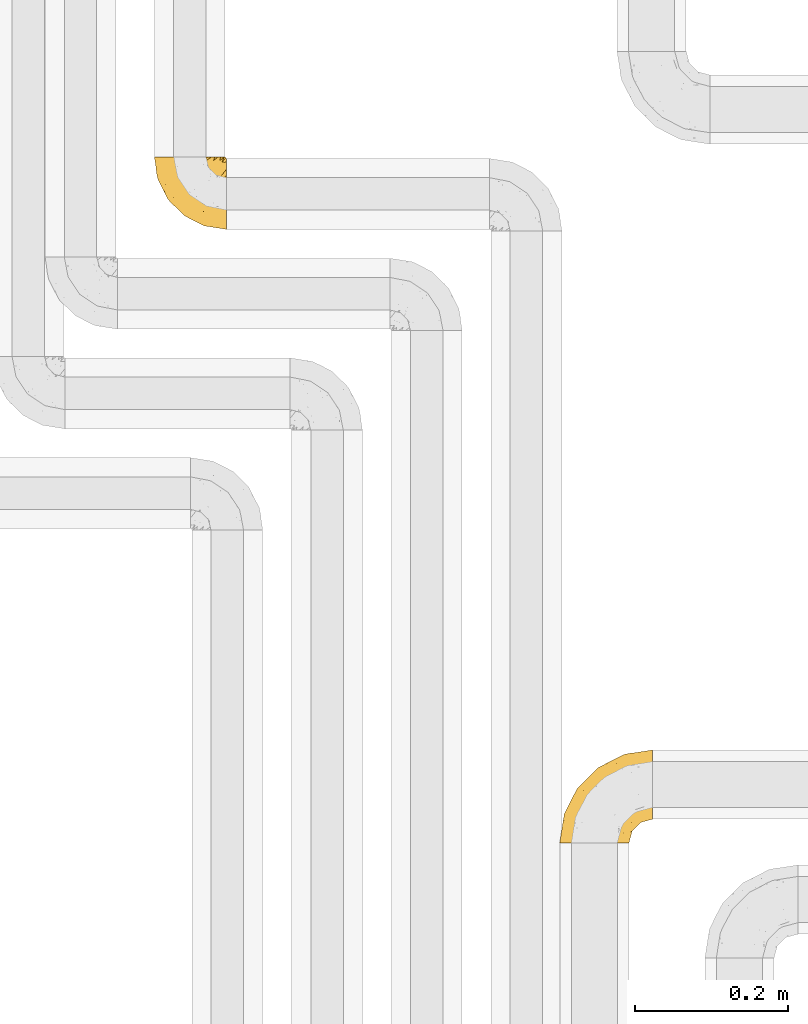
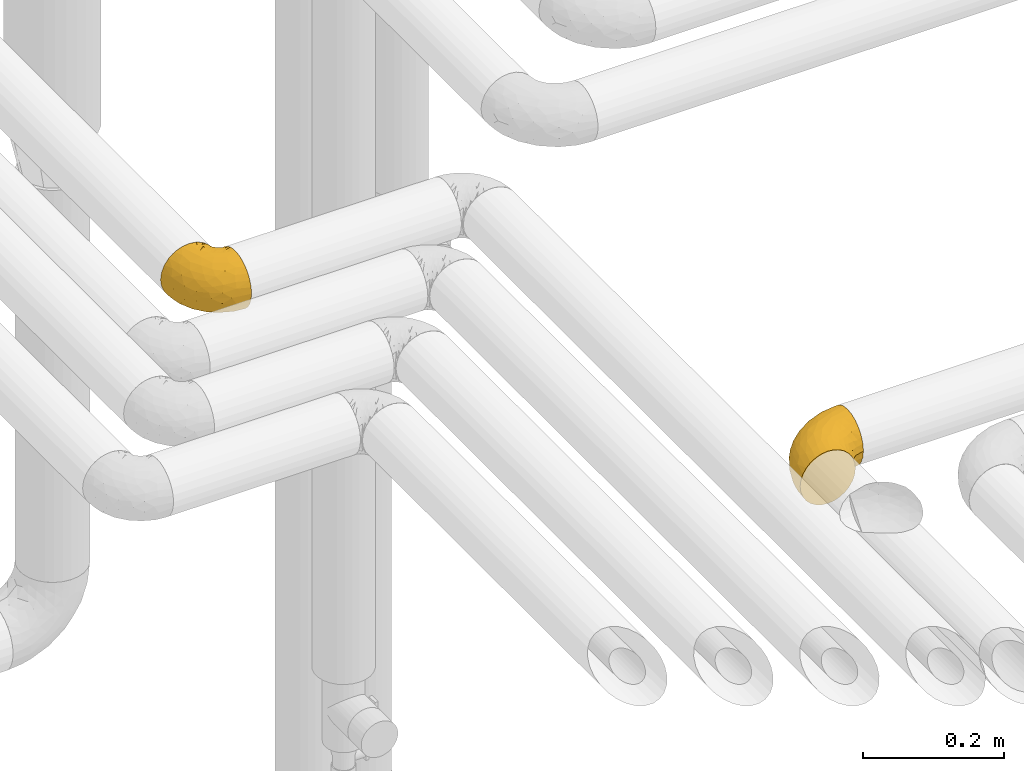
# One storey, part 263 of 827: 2 coverings.
"""IFC2X3 building model written with IfcOpenShell, lengths in millimetres."""

from ifc_helpers import new_model, entity, si_unit, converted_unit, derived_unit, direction, frame, origin, place, context, subcontext, project, spatial, faceted_brep, element, save


model = new_model("IFC2X3")

# Units and contexts
model_context = context("Model", 3, precision=0.01, world=origin(), true_north=direction((6.12303176911189e-17, 1.0)))
body_context = subcontext(model_context, "Body", "Model", "MODEL_VIEW")
ifc_project = project(units=[si_unit("LENGTHUNIT", "METRE", prefix="MILLI"), si_unit("AREAUNIT", "SQUARE_METRE"), si_unit("VOLUMEUNIT", "CUBIC_METRE"), converted_unit("PLANEANGLEUNIT", "DEGREE", entity("IfcRatioMeasure", 0.0174532925199433), si_unit("PLANEANGLEUNIT", "RADIAN"), dimensions=[0, 0, 0, 0, 0, 0, 0]), si_unit("MASSUNIT", "GRAM", prefix="KILO"), derived_unit("MASSDENSITYUNIT", [(si_unit("MASSUNIT", "GRAM", prefix="KILO"), 1), (si_unit("LENGTHUNIT", "METRE"), -3)]), derived_unit("MOMENTOFINERTIAUNIT", [(si_unit("LENGTHUNIT", "METRE"), 4)]), si_unit("TIMEUNIT", "SECOND"), si_unit("FREQUENCYUNIT", "HERTZ"), si_unit("THERMODYNAMICTEMPERATUREUNIT", "DEGREE_CELSIUS"), derived_unit("THERMALTRANSMITTANCEUNIT", [(si_unit("MASSUNIT", "GRAM", prefix="KILO"), 1), (si_unit("THERMODYNAMICTEMPERATUREUNIT", "KELVIN"), -1), (si_unit("TIMEUNIT", "SECOND"), -3)]), derived_unit("VOLUMETRICFLOWRATEUNIT", [(si_unit("LENGTHUNIT", "METRE"), 3), (si_unit("TIMEUNIT", "SECOND"), -1)]), derived_unit("MASSFLOWRATEUNIT", [(si_unit("MASSUNIT", "GRAM", prefix="KILO"), 1), (si_unit("TIMEUNIT", "SECOND"), -1)]), derived_unit("ROTATIONALFREQUENCYUNIT", [(si_unit("TIMEUNIT", "SECOND"), -1)]), si_unit("ELECTRICCURRENTUNIT", "AMPERE"), si_unit("ELECTRICVOLTAGEUNIT", "VOLT"), si_unit("POWERUNIT", "WATT"), si_unit("FORCEUNIT", "NEWTON", prefix="KILO"), si_unit("ILLUMINANCEUNIT", "LUX"), si_unit("LUMINOUSFLUXUNIT", "LUMEN"), si_unit("LUMINOUSINTENSITYUNIT", "CANDELA"), derived_unit("USERDEFINED", [(si_unit("MASSUNIT", "GRAM", prefix="KILO"), -1), (si_unit("LENGTHUNIT", "METRE"), -2), (si_unit("TIMEUNIT", "SECOND"), 3), (si_unit("LUMINOUSFLUXUNIT", "LUMEN"), 1)]), derived_unit("LINEARVELOCITYUNIT", [(si_unit("LENGTHUNIT", "METRE"), 1), (si_unit("TIMEUNIT", "SECOND"), -1)]), si_unit("PRESSUREUNIT", "PASCAL"), derived_unit("USERDEFINED", [(si_unit("LENGTHUNIT", "METRE"), -2), (si_unit("MASSUNIT", "GRAM", prefix="KILO"), 1), (si_unit("TIMEUNIT", "SECOND"), -2)]), derived_unit("LINEARFORCEUNIT", [(si_unit("MASSUNIT", "GRAM", prefix="KILO"), 1), (si_unit("LENGTHUNIT", "METRE"), 1), (si_unit("TIMEUNIT", "SECOND"), -2), (si_unit("LENGTHUNIT", "METRE"), -1)]), derived_unit("PLANARFORCEUNIT", [(si_unit("MASSUNIT", "GRAM", prefix="KILO"), 1), (si_unit("LENGTHUNIT", "METRE"), 1), (si_unit("TIMEUNIT", "SECOND"), -2), (si_unit("LENGTHUNIT", "METRE"), -2)])], contexts=[model_context])

# Site, building, storey
site_placement = place(None, origin())
site = spatial("IfcSite", under=ifc_project, at=site_placement, CompositionType="ELEMENT")
building_placement = place(site_placement, origin())
building = spatial("IfcBuilding", under=site, at=building_placement, CompositionType="ELEMENT")
storey_placement = place(building_placement, frame((0.0, 0.0, 28200.0)))
storey = spatial("IfcBuildingStorey", under=building, at=storey_placement, Name="08", CompositionType="ELEMENT", Elevation=28200.0)

# Coverings
covering_1_placement = place(storey_placement, frame((30819.81, 17333.41, 2952.2)))
element("IfcCovering", 1, at=covering_1_placement, inside=storey, Name=":ADSK_", ObjectType=":ADSK_", PredefinedType="INSULATION", context=body_context, shape_type="Brep", body=[
    faceted_brep([(95.8, 18.98, 83.91), (95.8, 11.67, 76.59), (95.8, 6.17, 67.83), (95.8, 2.75, 58.07), (95.8, 1.6, 47.8), (95.8, 2.75, 37.51), (95.8, 6.17, 27.74), (95.8, 11.68, 18.98), (95.8, 19.0, 11.67), (95.8, 27.76, 6.17), (95.8, 37.52, 2.75), (95.8, 47.8, 1.6), (95.8, 51.94, 2.06), (95.8, 55.01, 2.41), (95.8, 58.08, 2.75), (95.8, 62.96, 4.46), (95.8, 67.85, 6.17), (95.8, 72.23, 8.93), (95.8, 76.61, 11.68), (95.8, 80.26, 15.34), (95.8, 83.92, 19.0), (95.8, 89.42, 27.76), (95.8, 91.13, 32.64), (95.8, 92.84, 37.52), (95.8, 94.0, 47.8), (95.8, 92.84, 58.08), (95.8, 91.13, 62.96), (95.8, 89.42, 67.85), (95.8, 83.91, 76.61), (95.8, 80.25, 80.26), (95.8, 76.59, 83.92), (95.8, 72.21, 86.67), (95.8, 67.83, 89.42), (95.8, 62.95, 91.13), (95.8, 58.07, 92.84), (95.8, 55.0, 93.18), (95.8, 51.94, 93.53), (95.8, 47.8, 94.0), (95.8, 37.51, 92.84), (95.8, 27.74, 89.42), (94.0, 95.8, 47.8), (92.42, 95.8, 35.84), (87.81, 95.8, 24.7), (84.13, 95.8, 19.91), (80.46, 95.8, 15.13), (75.68, 95.8, 11.46), (70.9, 95.8, 7.78), (65.32, 95.8, 5.48), (59.75, 95.8, 3.17), (56.14, 95.8, 2.69), (54.06, 95.8, 2.42), (51.97, 95.8, 2.14), (47.8, 95.8, 1.6), (35.84, 95.8, 3.17), (24.7, 95.8, 7.78), (15.13, 95.8, 15.13), (7.78, 95.8, 24.7), (3.17, 95.8, 35.84), (1.6, 95.8, 47.8), (3.17, 95.8, 59.75), (7.78, 95.8, 70.9), (15.13, 95.8, 80.46), (24.7, 95.8, 87.81), (35.84, 95.8, 92.42), (47.8, 95.8, 94.0), (51.97, 95.8, 93.45), (56.14, 95.8, 92.9), (59.75, 95.8, 92.42), (65.32, 95.8, 90.11), (70.9, 95.8, 87.81), (75.68, 95.8, 84.13), (80.46, 95.8, 80.46), (84.13, 95.8, 75.68), (87.81, 95.8, 70.9), (92.42, 95.8, 59.75), (15.84, 60.58, 71.98), (6.99, 74.11, 63.6), (14.39, 51.59, 59.72), (6.21, 66.69, 47.8), (4.26, 76.19, 55.16), (3.39, 84.43, 47.8), (31.2, 31.2, 63.76), (26.47, 42.88, 72.22), (11.44, 79.41, 74.18), (47.66, 60.7, 92.52), (61.85, 61.85, 94.0), (59.25, 65.75, 94.0), (56.65, 69.64, 94.0), (54.05, 73.53, 94.0), (51.45, 77.43, 94.0), (19.8, 74.59, 82.14), (26.22, 54.72, 80.34), (31.58, 64.18, 87.52), (38.36, 37.94, 79.59), (51.54, 25.89, 78.25), (51.6, 34.73, 85.01), (55.97, 42.89, 90.25), (62.88, 49.83, 93.2), (41.35, 48.58, 87.23), (82.24, 22.41, 85.55), (40.88, 78.69, 93.0), (29.0, 81.64, 89.31), (74.06, 6.22, 61.31), (54.53, 12.11, 56.86), (57.98, 14.81, 68.34), (43.81, 21.61, 65.71), (38.22, 22.41, 56.99), (38.33, 30.12, 72.15), (74.76, 10.01, 70.34), (76.85, 15.36, 78.36), (84.43, 3.39, 47.8), (40.43, 19.59, 47.8), (30.01, 30.01, 47.8), (78.67, 41.19, 93.06), (92.06, 48.54, 94.0), (88.32, 49.28, 94.0), (85.6, 49.82, 94.0), (82.88, 50.37, 94.0), (80.15, 50.91, 94.0), (77.43, 51.45, 94.0), (76.36, 31.61, 89.88), (50.91, 80.15, 94.0), (50.37, 82.88, 94.0), (49.82, 85.6, 94.0), (49.28, 88.32, 94.0), (48.91, 90.19, 94.0), (48.54, 92.06, 94.0), (66.69, 6.21, 47.8), (73.53, 54.05, 94.0), (69.64, 56.65, 94.0), (65.75, 59.25, 94.0), (66.13, 24.66, 83.7), (19.59, 40.43, 47.8), (24.64, 35.17, 55.9), (53.56, 12.9, 47.8), (12.9, 53.56, 47.8), (82.81, 85.34, 81.75), (81.22, 78.44, 86.43), (86.57, 84.37, 79.8), (92.75, 89.05, 69.84), (89.68, 82.76, 79.5), (72.26, 86.31, 88.08), (64.73, 83.73, 91.6), (62.45, 77.31, 92.93), (60.63, 87.78, 92.43), (56.91, 87.91, 93.24), (58.14, 81.29, 93.36), (93.7, 93.97, 57.25), (83.4, 70.76, 89.41), (75.54, 63.67, 92.89), (79.46, 62.62, 92.66), (82.28, 90.64, 79.58), (76.25, 84.08, 86.51), (84.69, 76.28, 86.29), (90.18, 77.45, 83.91), (65.12, 88.72, 90.94), (71.71, 71.28, 91.94), (75.21, 68.09, 91.98), (78.6, 91.07, 82.79), (87.27, 57.47, 93.16), (87.92, 70.34, 88.76), (86.94, 91.35, 73.94), (86.1, 62.99, 91.89), (94.52, 94.52, 47.8), (66.23, 76.47, 92.22), (91.08, 69.96, 88.56), (71.77, 89.86, 87.72), (76.21, 78.94, 88.33), (68.59, 73.51, 92.18), (89.94, 89.62, 71.78), (76.25, 84.09, 9.09), (72.26, 86.3, 7.51), (78.6, 91.06, 12.8), (49.28, 88.32, 1.6), (48.54, 92.06, 1.6), (50.37, 82.88, 1.6), (49.82, 85.6, 1.6), (93.7, 93.97, 38.35), (89.95, 89.63, 23.84), (82.88, 50.37, 1.6), (85.6, 49.82, 1.6), (92.06, 48.54, 1.6), (88.32, 49.28, 1.6), (89.68, 82.77, 16.1), (87.92, 70.36, 6.84), (62.45, 77.31, 2.66), (66.24, 76.47, 3.37), (56.65, 69.64, 1.6), (59.25, 65.75, 1.6), (60.63, 87.78, 3.16), (56.91, 87.91, 2.35), (92.76, 89.06, 25.77), (82.28, 90.65, 16.02), (82.81, 85.35, 13.85), (54.05, 73.53, 1.6), (51.45, 77.43, 1.6), (58.14, 81.29, 2.23), (90.18, 77.46, 11.69), (84.7, 76.29, 9.31), (87.25, 57.47, 2.43), (75.58, 63.71, 2.71), (75.2, 68.11, 3.61), (83.39, 70.77, 6.18), (71.7, 71.31, 3.66), (81.22, 78.46, 9.17), (90.73, 69.52, 6.77), (79.47, 62.64, 2.93), (86.94, 91.35, 21.66), (65.75, 59.25, 1.6), (86.75, 84.6, 16.09), (86.08, 62.98, 3.7), (77.43, 51.45, 1.6), (73.53, 54.05, 1.6), (69.64, 56.65, 1.6), (64.73, 83.73, 3.99), (50.91, 80.15, 1.6), (65.12, 88.72, 4.65), (61.85, 61.85, 1.6), (68.62, 73.56, 3.43), (76.22, 78.96, 7.27), (74.03, 91.36, 9.46), (80.15, 50.91, 1.6), (49.81, 62.87, 2.4), (4.26, 76.19, 40.43), (19.95, 73.57, 13.57), (30.61, 56.07, 11.3), (25.71, 49.77, 18.65), (22.43, 44.73, 27.26), (15.85, 60.58, 23.61), (60.69, 47.64, 3.07), (40.49, 78.32, 2.69), (14.39, 51.59, 35.87), (6.99, 74.11, 31.99), (29.56, 76.04, 6.71), (11.45, 79.41, 21.41), (57.98, 14.82, 27.24), (74.06, 6.22, 34.26), (54.52, 12.12, 38.73), (43.47, 23.51, 26.97), (31.2, 31.2, 31.83), (33.27, 34.96, 23.4), (64.26, 33.86, 6.91), (74.29, 38.94, 3.4), (80.41, 30.23, 5.84), (41.67, 20.67, 35.73), (24.64, 35.17, 39.69), (73.62, 15.85, 17.6), (78.98, 22.59, 10.38), (53.69, 21.56, 20.6), (42.86, 55.94, 5.36), (79.66, 9.19, 24.84), (58.41, 25.79, 13.87), (47.11, 41.16, 9.06), (38.37, 37.95, 15.99)], [[[0, 1, 2, 3, 4, 5, 6, 7, 8, 9, 10, 11, 12, 13, 14, 15, 16, 17, 18, 19, 20, 21, 22, 23, 24, 25, 26, 27, 28, 29, 30, 31, 32, 33, 34, 35, 36, 37, 38, 39]], [[40, 41, 42, 43, 44, 45, 46, 47, 48, 49, 50, 51, 52, 53, 54, 55, 56, 57, 58, 59, 60, 61, 62, 63, 64, 65, 66, 67, 68, 69, 70, 71, 72, 73, 74]], [[75, 76, 77]], [[78, 79, 80]], [[77, 81, 82]], [[76, 75, 83]], [[84, 85, 86, 87, 88, 89]], [[90, 91, 92]], [[76, 60, 59]], [[93, 94, 95]], [[90, 62, 61]], [[83, 61, 60]], [[96, 97, 84]], [[98, 93, 95]], [[0, 39, 99]], [[100, 84, 89]], [[62, 101, 63]], [[2, 102, 3]], [[92, 84, 100]], [[103, 102, 104]], [[103, 105, 106]], [[93, 107, 94]], [[1, 108, 2]], [[92, 101, 90]], [[108, 1, 109]], [[102, 110, 3]], [[93, 82, 107]], [[102, 108, 104]], [[111, 106, 112]], [[109, 0, 99]], [[113, 37, 114, 115, 116, 117, 118, 119]], [[120, 38, 113]], [[100, 89, 121, 122, 123, 124, 125, 126, 64]], [[127, 102, 103]], [[97, 119, 128, 129, 130, 85]], [[99, 120, 131]], [[132, 133, 77]], [[59, 80, 79]], [[1, 0, 109]], [[98, 84, 92]], [[94, 109, 131]], [[120, 39, 38]], [[93, 91, 82]], [[104, 94, 105]], [[97, 113, 119]], [[95, 120, 96]], [[83, 90, 61]], [[91, 93, 98]], [[64, 63, 100]], [[100, 63, 101]], [[77, 76, 79]], [[133, 106, 81]], [[84, 97, 85]], [[113, 96, 120]], [[113, 97, 96]], [[37, 113, 38]], [[110, 102, 127]], [[110, 4, 3]], [[103, 111, 134, 127]], [[90, 75, 91]], [[82, 81, 107]], [[91, 75, 82]], [[77, 82, 75]], [[76, 83, 60]], [[90, 83, 75]], [[105, 107, 81]], [[94, 131, 95]], [[105, 94, 107]], [[109, 94, 104]], [[120, 95, 131]], [[98, 95, 96]], [[84, 98, 96]], [[98, 92, 91]], [[106, 105, 81]], [[103, 104, 105]], [[133, 132, 112]], [[103, 106, 111]], [[77, 78, 135, 132]], [[106, 133, 112]], [[77, 133, 81]], [[120, 99, 39]], [[109, 99, 131]], [[59, 58, 80]], [[59, 79, 76]], [[90, 101, 62]], [[100, 101, 92]], [[2, 108, 102]], [[109, 104, 108]], [[78, 77, 79]], [[136, 137, 138]], [[27, 139, 140]], [[141, 142, 143]], [[144, 145, 121]], [[146, 89, 88]], [[147, 139, 25]], [[148, 149, 150]], [[136, 151, 152]], [[147, 40, 74]], [[24, 147, 25]], [[140, 153, 154]], [[33, 116, 34]], [[73, 72, 151]], [[114, 37, 36, 35, 34, 116, 115]], [[146, 155, 144]], [[156, 85, 130]], [[157, 149, 148]], [[151, 158, 152]], [[117, 33, 159]], [[29, 154, 160]], [[161, 74, 73]], [[162, 128, 119]], [[66, 65, 64, 126, 125, 124, 123, 122, 67]], [[163, 147, 24]], [[27, 140, 28]], [[149, 129, 150]], [[139, 27, 26, 25]], [[68, 144, 69]], [[129, 128, 150]], [[164, 87, 86]], [[130, 129, 149]], [[122, 145, 67]], [[154, 153, 148]], [[162, 119, 159]], [[165, 30, 160]], [[150, 160, 148]], [[128, 162, 150]], [[30, 165, 31]], [[145, 144, 68]], [[89, 146, 144]], [[87, 164, 143]], [[166, 155, 142]], [[88, 87, 143]], [[162, 160, 150]], [[160, 30, 29]], [[154, 29, 28]], [[140, 154, 28]], [[160, 154, 148]], [[140, 137, 153]], [[157, 148, 153]], [[156, 130, 157]], [[153, 137, 157]], [[157, 137, 156]], [[167, 137, 136]], [[168, 85, 156]], [[152, 168, 167]], [[167, 168, 156]], [[164, 152, 141]], [[71, 158, 72]], [[152, 167, 136]], [[88, 142, 146]], [[144, 155, 69]], [[146, 142, 155]], [[70, 166, 71]], [[142, 141, 166]], [[70, 69, 155]], [[141, 158, 71]], [[161, 73, 151]], [[138, 137, 140]], [[161, 136, 169]], [[136, 161, 151]], [[74, 161, 169]], [[152, 158, 141]], [[151, 72, 158]], [[168, 152, 164]], [[137, 167, 156]], [[164, 86, 168]], [[85, 168, 86]], [[116, 33, 117]], [[130, 149, 157]], [[67, 145, 68]], [[121, 89, 144]], [[145, 122, 121]], [[40, 147, 163]], [[169, 147, 74]], [[159, 33, 32]], [[162, 159, 32]], [[159, 119, 118, 117]], [[139, 147, 169]], [[139, 169, 138]], [[162, 32, 31]], [[141, 143, 164]], [[88, 143, 142]], [[71, 166, 141]], [[155, 166, 70]], [[139, 138, 140]], [[169, 136, 138]], [[160, 162, 165]], [[162, 31, 165]], [[170, 171, 172]], [[173, 174, 52, 51, 50, 49, 48, 175, 176]], [[177, 178, 41]], [[179, 15, 180]], [[12, 11, 181, 182, 180, 14, 13]], [[183, 21, 20]], [[19, 18, 184]], [[185, 186, 187]], [[186, 188, 187]], [[43, 172, 44]], [[189, 190, 47]], [[23, 22, 21, 191]], [[170, 192, 193]], [[40, 163, 177]], [[194, 195, 196]], [[24, 23, 177]], [[197, 198, 183]], [[199, 15, 179]], [[47, 46, 189]], [[200, 201, 202]], [[201, 203, 204]], [[205, 206, 184]], [[207, 41, 178]], [[16, 15, 199]], [[14, 180, 15]], [[202, 201, 198]], [[208, 201, 200]], [[163, 24, 177]], [[48, 47, 190]], [[196, 195, 189]], [[197, 184, 202]], [[204, 193, 209]], [[210, 211, 212]], [[206, 212, 213]], [[205, 17, 210]], [[184, 206, 202]], [[210, 212, 206]], [[185, 194, 214]], [[189, 215, 190]], [[216, 45, 214]], [[186, 171, 170]], [[189, 216, 196]], [[197, 20, 19]], [[194, 185, 187]], [[197, 183, 20]], [[184, 197, 19]], [[197, 202, 198]], [[206, 200, 202]], [[204, 183, 198]], [[201, 208, 203]], [[203, 208, 217]], [[204, 198, 201]], [[217, 188, 218]], [[193, 219, 170]], [[171, 186, 185]], [[170, 218, 186]], [[170, 219, 218]], [[42, 207, 192]], [[171, 220, 172]], [[216, 189, 46]], [[214, 194, 196]], [[44, 220, 45]], [[214, 196, 216]], [[216, 46, 45]], [[214, 45, 220]], [[192, 43, 42]], [[204, 203, 219]], [[207, 193, 192]], [[209, 193, 178]], [[41, 207, 42]], [[193, 207, 178]], [[43, 192, 172]], [[170, 172, 192]], [[204, 219, 193]], [[219, 203, 218]], [[217, 218, 203]], [[188, 186, 218]], [[206, 213, 200]], [[208, 200, 213]], [[199, 210, 16]], [[215, 189, 195]], [[215, 175, 190]], [[175, 48, 190]], [[199, 179, 221, 211]], [[210, 199, 211]], [[23, 191, 177]], [[40, 177, 41]], [[178, 177, 191]], [[21, 183, 191]], [[209, 191, 183]], [[205, 18, 17]], [[17, 16, 210]], [[171, 185, 214]], [[172, 220, 44]], [[214, 220, 171]], [[191, 209, 178]], [[204, 209, 183]], [[206, 205, 210]], [[18, 205, 184]], [[222, 195, 194, 187, 188, 217]], [[57, 223, 80]], [[224, 225, 226]], [[226, 227, 228]], [[229, 217, 208, 213, 212, 211]], [[230, 52, 174, 173, 176, 175, 215, 195]], [[231, 232, 228]], [[231, 78, 223]], [[223, 57, 232]], [[224, 233, 225]], [[233, 54, 53]], [[234, 232, 56]], [[56, 55, 234]], [[234, 224, 228]], [[235, 236, 237]], [[224, 55, 54]], [[238, 239, 240]], [[52, 230, 53]], [[241, 242, 243]], [[239, 244, 245]], [[11, 10, 242]], [[236, 6, 5]], [[7, 246, 8]], [[8, 247, 9]], [[238, 248, 235]], [[222, 229, 249]], [[242, 211, 221, 179, 180, 182, 181, 11]], [[233, 53, 230]], [[111, 112, 244]], [[250, 6, 236]], [[247, 251, 241]], [[6, 250, 7]], [[127, 236, 110]], [[249, 229, 252]], [[247, 8, 246]], [[235, 246, 250]], [[236, 5, 110]], [[235, 244, 238]], [[237, 236, 127]], [[243, 9, 247]], [[252, 229, 241]], [[56, 232, 57]], [[222, 230, 195]], [[225, 249, 252]], [[249, 233, 230]], [[54, 233, 224]], [[231, 228, 227]], [[245, 132, 231]], [[249, 225, 233]], [[226, 225, 253]], [[235, 250, 236]], [[246, 7, 250]], [[251, 247, 246]], [[243, 247, 241]], [[248, 246, 235]], [[252, 251, 253]], [[229, 222, 217]], [[230, 222, 249]], [[5, 4, 110]], [[237, 127, 134, 111]], [[238, 244, 239]], [[224, 234, 55]], [[232, 234, 228]], [[242, 241, 229]], [[10, 9, 243]], [[211, 242, 229]], [[10, 243, 242]], [[80, 223, 78]], [[80, 58, 57]], [[231, 223, 232]], [[227, 240, 239]], [[224, 226, 228]], [[240, 226, 253]], [[227, 239, 245]], [[226, 240, 227]], [[251, 248, 253]], [[240, 253, 248]], [[244, 235, 237]], [[237, 111, 244]], [[132, 245, 112]], [[112, 245, 244]], [[135, 78, 231, 132]], [[227, 245, 231]], [[248, 238, 240]], [[246, 248, 251]], [[251, 252, 241]], [[225, 252, 253]]]),
])
covering_2_placement = place(storey_placement, frame((31348.29, 16533.61, 2953.25)))
element("IfcCovering", 2, at=covering_2_placement, inside=storey, Name=":ADSK_", ObjectType=":ADSK_", PredefinedType="INSULATION", context=body_context, shape_type="Brep", body=[
    faceted_brep([(36.69, 1.6, 90.76), (27.15, 1.6, 87.42), (18.59, 1.6, 82.04), (11.44, 1.6, 74.89), (6.06, 1.6, 66.33), (2.73, 1.6, 56.79), (1.6, 1.6, 46.75), (2.73, 1.6, 36.69), (6.07, 1.6, 27.15), (11.45, 1.6, 18.59), (18.6, 1.6, 11.44), (27.16, 1.6, 6.06), (36.7, 1.6, 2.73), (46.75, 1.6, 1.6), (56.8, 1.6, 2.73), (66.34, 1.6, 6.07), (74.9, 1.6, 11.45), (82.05, 1.6, 18.6), (87.43, 1.6, 27.16), (90.76, 1.6, 36.7), (91.9, 1.6, 46.75), (90.76, 1.6, 56.8), (87.42, 1.6, 66.34), (82.04, 1.6, 74.9), (74.89, 1.6, 82.05), (66.33, 1.6, 87.43), (56.79, 1.6, 90.76), (46.75, 1.6, 91.9), (122.75, 33.98, 35.06), (122.75, 38.49, 24.17), (122.75, 45.67, 14.82), (122.75, 55.02, 7.64), (122.75, 65.91, 3.13), (122.75, 77.6, 1.6), (122.75, 89.28, 3.13), (122.75, 100.17, 7.64), (122.75, 109.52, 14.82), (122.75, 116.7, 24.17), (122.75, 121.21, 35.06), (122.75, 122.75, 46.75), (122.75, 121.21, 58.43), (122.75, 116.7, 69.32), (122.75, 109.52, 78.67), (122.75, 100.17, 85.85), (122.75, 89.28, 90.36), (122.75, 77.6, 91.9), (122.75, 65.91, 90.36), (122.75, 55.02, 85.85), (122.75, 45.67, 78.67), (122.75, 38.49, 69.32), (122.75, 33.98, 58.43), (122.75, 32.45, 46.75), (24.73, 72.81, 46.75), (29.08, 77.17, 55.2), (38.13, 86.21, 46.75), (85.31, 116.82, 46.75), (93.59, 118.49, 54.53), (100.54, 119.23, 46.75), (63.54, 105.14, 59.63), (38.98, 85.37, 62.07), (50.71, 89.33, 71.86), (93.33, 116.14, 62.65), (75.2, 105.06, 71.33), (100.46, 112.15, 72.93), (41.6, 22.95, 91.2), (80.86, 89.91, 86.31), (94.87, 103.39, 80.89), (67.96, 93.6, 79.49), (52.16, 51.41, 90.68), (52.1, 67.71, 86.84), (36.74, 43.53, 87.38), (17.11, 30.91, 76.87), (23.24, 23.58, 83.73), (29.18, 50.07, 81.03), (52.53, 30.68, 91.9), (60.77, 43.01, 91.9), (69.01, 55.34, 91.9), (100.68, 83.48, 91.03), (103.79, 94.96, 87.58), (16.37, 57.29, 56.52), (7.52, 39.03, 46.75), (7.31, 30.66, 60.4), (93.66, 71.81, 91.9), (102.83, 73.63, 91.9), (112.01, 75.46, 91.9), (18.17, 51.57, 67.87), (71.97, 73.13, 90.35), (9.83, 23.16, 69.57), (5.11, 23.8, 46.75), (45.97, 75.6, 79.91), (48.88, 12.33, 91.9), (50.71, 21.51, 91.9), (22.83, 50.46, 74.99), (51.54, 99.61, 46.75), (81.33, 63.57, 91.9), (31.74, 21.26, 88.53), (32.48, 69.54, 72.65), (68.42, 108.21, 46.75), (25.33, 68.42, 62.97), (16.13, 55.92, 46.75), (92.29, 19.36, 66.2), (94.12, 15.76, 56.6), (100.97, 26.13, 59.89), (95.91, 62.78, 90.95), (107.9, 63.65, 90.22), (87.24, 24.34, 76.64), (95.46, 28.46, 71.58), (90.41, 33.53, 79.99), (74.17, 39.46, 89.54), (83.77, 51.05, 89.97), (76.72, 10.94, 81.32), (84.44, 14.55, 74.56), (76.42, 22.21, 84.15), (90.07, 57.05, 90.37), (99.69, 54.0, 87.82), (61.74, 29.19, 90.98), (58.16, 18.85, 90.96), (112.6, 52.84, 85.14), (110.45, 31.47, 58.11), (107.32, 28.31, 46.75), (108.48, 43.0, 78.39), (66.63, 16.9, 88.22), (115.23, 35.98, 66.06), (105.79, 33.91, 68.6), (89.6, 9.97, 63.78), (69.39, 25.93, 88.42), (66.99, 35.61, 90.61), (102.31, 47.45, 83.8), (99.54, 38.26, 77.98), (55.27, 11.7, 91.22), (82.03, 30.13, 83.46), (94.71, 12.12, 46.75), (96.03, 17.02, 46.75), (94.11, 44.39, 84.66), (84.21, 39.83, 86.33), (101.67, 22.67, 46.75), (112.22, 29.63, 46.75), (108.48, 43.0, 15.1), (102.31, 47.45, 9.69), (99.54, 38.26, 15.52), (94.11, 44.38, 8.83), (110.46, 31.47, 35.39), (76.74, 10.93, 12.18), (50.71, 21.51, 1.6), (58.17, 18.84, 2.53), (55.27, 11.7, 2.27), (94.12, 15.76, 36.9), (92.3, 19.36, 27.31), (100.98, 26.14, 33.62), (69.41, 25.94, 5.07), (76.44, 22.21, 9.36), (66.65, 16.9, 5.27), (115.24, 35.98, 27.43), (102.83, 73.63, 1.6), (112.01, 75.46, 1.6), (82.05, 30.12, 10.05), (87.25, 24.33, 16.87), (112.6, 52.84, 8.35), (107.9, 63.65, 3.27), (93.66, 71.81, 1.6), (95.48, 28.45, 21.94), (89.6, 9.97, 29.72), (60.77, 43.01, 1.6), (69.01, 55.34, 1.6), (74.17, 39.46, 3.96), (48.88, 12.33, 1.6), (84.45, 14.54, 18.95), (95.91, 62.78, 2.54), (90.07, 57.05, 3.12), (81.33, 63.57, 1.6), (61.75, 29.2, 2.51), (83.77, 51.05, 3.52), (84.21, 39.81, 7.17), (52.53, 30.68, 1.6), (90.42, 33.52, 13.52), (67.0, 35.61, 2.88), (99.69, 54.0, 5.67), (105.8, 33.91, 24.89), (94.87, 103.39, 12.6), (80.86, 89.91, 7.18), (67.95, 93.6, 14.0), (75.17, 105.05, 22.16), (50.65, 89.27, 21.61), (71.97, 73.13, 3.14), (52.08, 67.67, 6.65), (32.46, 69.49, 20.82), (38.98, 85.36, 31.41), (103.79, 94.96, 5.91), (100.68, 83.48, 2.46), (63.54, 105.14, 33.87), (93.32, 116.13, 30.84), (93.59, 118.49, 38.96), (100.44, 112.15, 20.56), (52.17, 51.41, 2.81), (36.75, 43.51, 6.1), (41.61, 22.95, 2.29), (7.31, 30.66, 33.08), (17.12, 30.91, 16.61), (16.37, 57.3, 36.96), (23.26, 23.58, 9.75), (18.17, 51.56, 25.61), (25.33, 68.41, 30.5), (9.84, 23.16, 23.91), (29.19, 50.07, 12.45), (22.84, 50.45, 18.49), (31.75, 21.25, 4.96), (45.96, 75.56, 13.56), (29.07, 77.16, 38.28)], [[[0, 1, 2, 3, 4, 5, 6, 7, 8, 9, 10, 11, 12, 13, 14, 15, 16, 17, 18, 19, 20, 21, 22, 23, 24, 25, 26, 27]], [[28, 29, 30, 31, 32, 33, 34, 35, 36, 37, 38, 39, 40, 41, 42, 43, 44, 45, 46, 47, 48, 49, 50, 51]], [[52, 53, 54]], [[55, 56, 57]], [[58, 59, 60]], [[61, 62, 63]], [[27, 64, 0]], [[65, 66, 67]], [[41, 40, 61]], [[68, 69, 70]], [[66, 43, 42]], [[63, 42, 41]], [[71, 72, 73]], [[72, 2, 1]], [[68, 74, 75, 76]], [[45, 44, 77]], [[43, 78, 44]], [[79, 80, 81]], [[77, 82, 83, 84, 45]], [[79, 81, 85]], [[71, 2, 72]], [[65, 86, 77]], [[4, 81, 5]], [[66, 65, 78]], [[4, 3, 87]], [[81, 88, 5]], [[63, 66, 42]], [[68, 70, 64]], [[67, 60, 89]], [[71, 3, 2]], [[64, 27, 90, 91, 74]], [[92, 71, 73]], [[40, 57, 56]], [[59, 93, 54]], [[86, 76, 94, 82]], [[1, 0, 95]], [[58, 62, 61]], [[60, 96, 89]], [[85, 81, 87]], [[56, 97, 58]], [[65, 67, 69]], [[87, 81, 4]], [[67, 89, 69]], [[61, 63, 41]], [[95, 72, 1]], [[73, 72, 70]], [[69, 73, 70]], [[73, 89, 96]], [[3, 71, 87]], [[85, 87, 71]], [[58, 61, 56]], [[59, 58, 93]], [[76, 86, 68]], [[69, 89, 73]], [[68, 86, 69]], [[65, 69, 86]], [[68, 64, 74]], [[95, 64, 70]], [[98, 79, 85]], [[79, 52, 99, 80]], [[66, 62, 67]], [[62, 58, 60]], [[62, 60, 67]], [[59, 98, 96]], [[59, 96, 60]], [[96, 85, 92]], [[88, 81, 80]], [[88, 6, 5]], [[66, 63, 62]], [[64, 95, 0]], [[72, 95, 70]], [[77, 44, 78]], [[86, 82, 77]], [[40, 39, 57]], [[96, 98, 85]], [[40, 56, 61]], [[66, 78, 43]], [[77, 78, 65]], [[79, 98, 53]], [[96, 92, 73]], [[85, 71, 92]], [[97, 56, 55]], [[97, 93, 58]], [[53, 98, 59]], [[54, 53, 59]], [[79, 53, 52]], [[100, 101, 102]], [[46, 45, 84, 83]], [[103, 104, 82]], [[82, 104, 83]], [[105, 106, 107]], [[108, 109, 76]], [[110, 111, 112]], [[103, 113, 114]], [[115, 74, 116]], [[48, 47, 117]], [[118, 102, 119]], [[49, 48, 120]], [[74, 91, 116]], [[116, 121, 115]], [[49, 122, 50]], [[123, 106, 102]], [[124, 111, 22]], [[125, 126, 115]], [[23, 22, 111]], [[24, 110, 121]], [[120, 127, 128]], [[90, 26, 129]], [[27, 26, 90]], [[121, 125, 115]], [[24, 121, 25]], [[130, 105, 107]], [[129, 25, 116]], [[21, 20, 131]], [[120, 123, 122]], [[112, 105, 130]], [[50, 118, 51]], [[21, 124, 22]], [[101, 131, 132]], [[117, 120, 48]], [[24, 23, 110]], [[127, 114, 133]], [[75, 108, 76]], [[107, 134, 130]], [[133, 114, 113]], [[129, 116, 91]], [[25, 121, 116]], [[121, 112, 125]], [[75, 74, 115]], [[101, 135, 102]], [[131, 101, 21]], [[101, 100, 124]], [[128, 127, 133]], [[119, 136, 51, 118]], [[104, 47, 46]], [[83, 104, 46]], [[117, 104, 114]], [[101, 124, 21]], [[111, 124, 100]], [[102, 118, 123]], [[133, 134, 107]], [[111, 110, 23]], [[114, 104, 103]], [[94, 76, 109]], [[121, 110, 112]], [[122, 118, 50]], [[134, 109, 108]], [[133, 107, 128]], [[112, 108, 125]], [[126, 125, 108]], [[108, 75, 126]], [[75, 115, 126]], [[109, 134, 133]], [[130, 108, 112]], [[108, 130, 134]], [[105, 112, 111]], [[111, 100, 105]], [[106, 105, 100]], [[102, 106, 100]], [[128, 106, 123]], [[90, 129, 91]], [[25, 129, 26]], [[104, 117, 47]], [[117, 114, 127]], [[82, 94, 103]], [[113, 94, 109]], [[94, 113, 103]], [[133, 113, 109]], [[106, 128, 107]], [[123, 120, 128]], [[120, 122, 49]], [[118, 122, 123]], [[135, 101, 132]], [[135, 119, 102]], [[117, 127, 120]], [[30, 29, 137]], [[138, 139, 140]], [[51, 136, 119, 141]], [[142, 17, 16]], [[143, 144, 145]], [[146, 147, 148]], [[149, 150, 151]], [[152, 29, 28]], [[33, 32, 153, 154]], [[150, 155, 156]], [[157, 31, 30]], [[153, 158, 159]], [[29, 152, 137]], [[148, 141, 119]], [[156, 160, 147]], [[148, 135, 146]], [[137, 138, 157]], [[19, 161, 146]], [[162, 163, 164]], [[14, 13, 165]], [[153, 32, 158]], [[147, 161, 166]], [[18, 17, 166]], [[167, 168, 169]], [[166, 150, 156]], [[151, 150, 142]], [[151, 170, 149]], [[151, 16, 15]], [[171, 140, 172]], [[165, 143, 145]], [[173, 170, 144]], [[142, 166, 17]], [[19, 131, 20]], [[144, 170, 151]], [[18, 161, 19]], [[173, 144, 143]], [[140, 139, 174]], [[171, 164, 163]], [[164, 172, 155]], [[151, 15, 144]], [[145, 15, 14]], [[173, 162, 170]], [[149, 175, 164]], [[19, 146, 131]], [[132, 131, 146]], [[160, 148, 147]], [[159, 158, 167]], [[135, 132, 146]], [[158, 32, 31]], [[157, 158, 31]], [[167, 158, 176]], [[166, 161, 18]], [[146, 161, 147]], [[148, 177, 141]], [[171, 168, 140]], [[171, 163, 169]], [[151, 142, 16]], [[166, 142, 150]], [[152, 141, 177]], [[51, 141, 28]], [[138, 140, 176]], [[172, 140, 174]], [[175, 149, 170]], [[164, 150, 149]], [[170, 162, 175]], [[162, 164, 175]], [[155, 172, 174]], [[171, 172, 164]], [[155, 174, 156]], [[164, 155, 150]], [[160, 156, 174]], [[147, 166, 156]], [[139, 160, 174]], [[148, 160, 177]], [[15, 145, 144]], [[165, 145, 14]], [[137, 157, 30]], [[158, 157, 176]], [[168, 167, 176]], [[169, 159, 167]], [[140, 168, 176]], [[169, 168, 171]], [[137, 177, 139]], [[160, 139, 177]], [[141, 152, 28]], [[137, 152, 177]], [[148, 119, 135]], [[157, 138, 176]], [[139, 138, 137]], [[178, 179, 180]], [[181, 180, 182]], [[179, 183, 184]], [[185, 186, 182]], [[187, 188, 179]], [[188, 33, 154, 153, 159]], [[181, 189, 190]], [[35, 34, 187]], [[191, 38, 190]], [[192, 178, 181]], [[179, 184, 180]], [[192, 190, 37]], [[37, 190, 38]], [[36, 35, 178]], [[54, 93, 186]], [[35, 187, 178]], [[193, 194, 184]], [[195, 173, 143, 165, 13]], [[195, 193, 173]], [[193, 163, 162, 173]], [[13, 12, 195]], [[8, 7, 196]], [[9, 197, 10]], [[198, 80, 99, 52]], [[196, 7, 88]], [[197, 199, 10]], [[182, 189, 181]], [[200, 198, 201]], [[200, 196, 198]], [[9, 8, 202]], [[194, 199, 203]], [[192, 37, 36]], [[80, 196, 88]], [[183, 159, 169, 163]], [[188, 34, 33]], [[202, 200, 197]], [[185, 203, 204]], [[202, 8, 196]], [[10, 199, 11]], [[12, 11, 205]], [[38, 191, 57]], [[189, 97, 191]], [[203, 199, 197]], [[205, 199, 194]], [[204, 203, 197]], [[184, 203, 206]], [[200, 202, 196]], [[197, 9, 202]], [[207, 54, 186]], [[97, 55, 191]], [[194, 203, 184]], [[183, 163, 193]], [[184, 206, 180]], [[183, 193, 184]], [[205, 195, 12]], [[193, 195, 194]], [[80, 198, 196]], [[207, 186, 201]], [[182, 180, 206]], [[181, 178, 180]], [[185, 182, 206]], [[182, 186, 189]], [[203, 185, 206]], [[185, 200, 201]], [[7, 6, 88]], [[178, 192, 36]], [[190, 192, 181]], [[199, 205, 11]], [[195, 205, 194]], [[159, 183, 188]], [[179, 188, 183]], [[57, 191, 55]], [[57, 39, 38]], [[189, 191, 190]], [[188, 187, 34]], [[178, 187, 179]], [[186, 93, 189]], [[197, 200, 204]], [[185, 204, 200]], [[189, 93, 97]], [[207, 198, 52]], [[185, 201, 186]], [[198, 207, 201]], [[54, 207, 52]]]),
])

save(model, "model.ifc")
